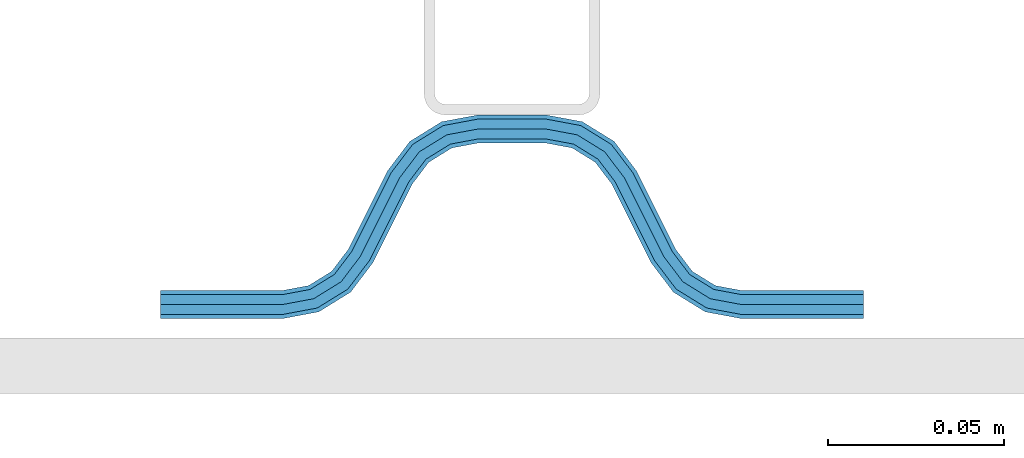
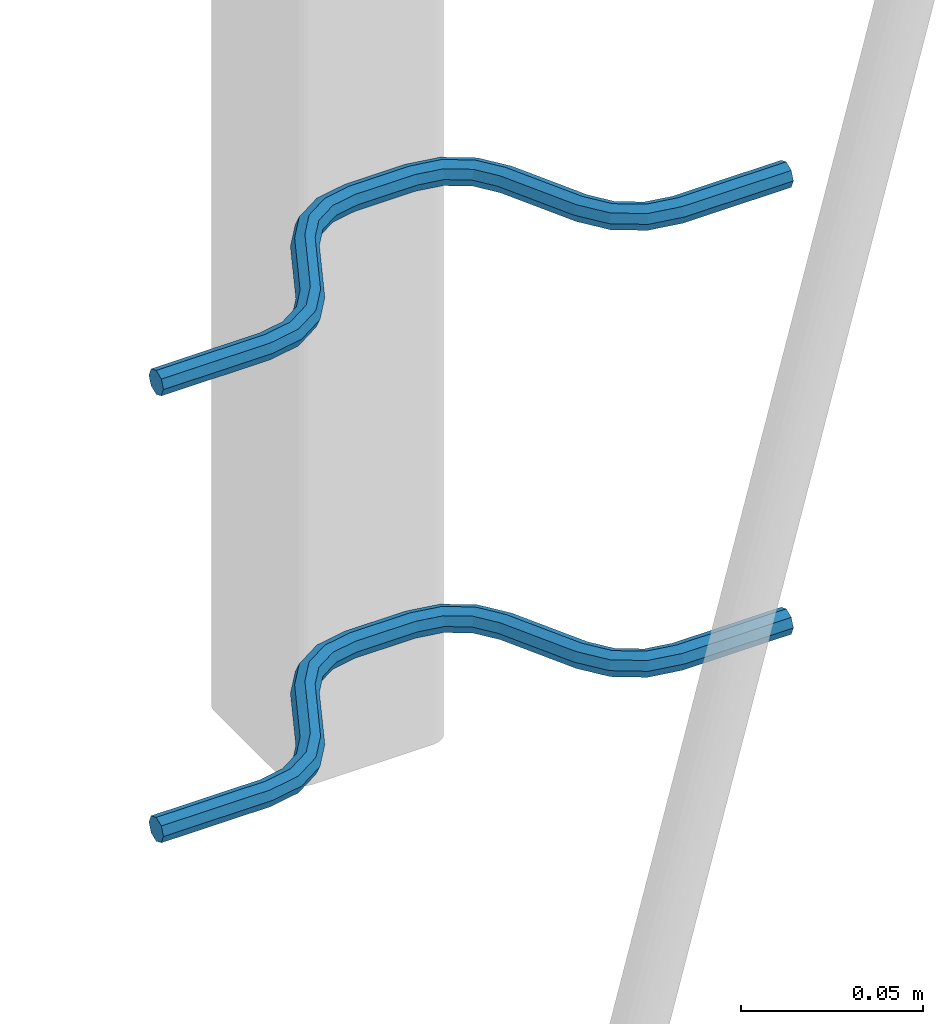
# One storey, part 5 of 5: 2 beams, 2 elements without a shape of their own.
"""IFC2X3 building model written with IfcOpenShell, lengths in millimetres."""

import ifcopenshell
import ifcopenshell.guid

model = None  # the IFC model being written
_history = None  # IfcOwnerHistory: only IFC2X3 demands one
_inside = {}  # id of a spatial element -> (the spatial element, [elements in it])
_under = {}  # id of a project, library or spatial element -> (it, [spatial elements below it])
_declared = {}  # id of a project -> (the project, [libraries it declares])
_typed = {}  # id of a type object -> (the type object, [elements of that type])
_made_of = {}  # id of a material, layer set ... -> (it, [elements and type objects made of it])


def new_model(schema):
    """Start an empty IFC model of exactly this schema.

    Asked for "IFC4X3", IfcOpenShell would pick the latest addendum, in which some entities
    have other attributes; the version numbers below select the first issue.
    IFC2X3 requires an IfcOwnerHistory on every rooted entity: one is made here for all.
    """
    global model, _history
    if schema == "IFC4X3":
        model = ifcopenshell.file(schema_version=(4, 3, 0, 0))
    else:
        model = ifcopenshell.file(schema=schema)
    _inside.clear()
    _under.clear()
    _declared.clear()
    _typed.clear()
    _made_of.clear()
    _history = None
    if model.schema == "IFC2X3":
        org = make("IfcOrganization", Name="unknown")
        user = make(
            "IfcPersonAndOrganization",
            ThePerson=make("IfcPerson", FamilyName="unknown"),
            TheOrganization=org,
        )
        app = make(
            "IfcApplication",
            ApplicationDeveloper=org,
            Version="unknown",
            ApplicationFullName="unknown",
            ApplicationIdentifier="unknown",
        )
        _history = make(
            "IfcOwnerHistory",
            OwningUser=user,
            OwningApplication=app,
            ChangeAction="ADDED",
            CreationDate=0,
        )
    return model


def make(cls, **values):
    """One entity of the class cls with the attributes given. An attribute that is None is left unset."""
    return model.create_entity(
        cls, **{name: value for name, value in values.items() if value is not None}
    )


def rooted(cls, **values):
    """An entity with a GlobalId (a new one), such as an element, a storey or a relation."""
    return make(cls, GlobalId=ifcopenshell.guid.new(), OwnerHistory=_history, **values)


def si_unit(unit_type, name, prefix=None):
    """IfcSIUnit, for example si_unit("LENGTHUNIT", "METRE", prefix="MILLI")."""
    return make("IfcSIUnit", UnitType=unit_type, Prefix=prefix, Name=name)


def assignment(units):
    """IfcUnitAssignment: the units of a project."""
    return None if units is None else make("IfcUnitAssignment", Units=units)


def point(xyz):
    """IfcCartesianPoint."""
    return None if xyz is None else make("IfcCartesianPoint", Coordinates=xyz)


def direction(xyz):
    """IfcDirection."""
    return None if xyz is None else make("IfcDirection", DirectionRatios=xyz)


def frame(location, z_axis=None, x_axis=None):
    """IfcAxis2Placement3D, a coordinate frame: its origin and axes. An axis left out is left unset."""
    return make(
        "IfcAxis2Placement3D",
        Location=point(location),
        Axis=direction(z_axis),
        RefDirection=direction(x_axis),
    )


def origin_with_axes():
    """The frame at (0, 0, 0) with the z axis (0, 0, 1) and the x axis (1, 0, 0) written out."""
    return frame((0.0, 0.0, 0.0), z_axis=(0.0, 0.0, 1.0), x_axis=(1.0, 0.0, 0.0))


def place(relative_to, where):
    """IfcLocalPlacement: puts the frame where relative to a parent placement (None: the world)."""
    return make(
        "IfcLocalPlacement", PlacementRelTo=relative_to, RelativePlacement=where
    )


def context(
    kind, dimensions, precision=None, world=None, true_north=None, identifier=None
):
    """IfcGeometricRepresentationContext, for example the 3D "Model" context."""
    return make(
        "IfcGeometricRepresentationContext",
        ContextIdentifier=identifier,
        ContextType=kind,
        CoordinateSpaceDimension=dimensions,
        Precision=precision,
        WorldCoordinateSystem=world,
        TrueNorth=true_north,
    )


def subcontext(parent, identifier, kind, view, scale=None):
    """IfcGeometricRepresentationSubContext, for example "Body" below "Model"."""
    return make(
        "IfcGeometricRepresentationSubContext",
        ContextIdentifier=identifier,
        ContextType=kind,
        ParentContext=parent,
        TargetScale=scale,
        TargetView=view,
    )


def project(units=None, contexts=None):
    """IfcProject with its units and contexts."""
    return rooted(
        "IfcProject",
        Name="project",
        RepresentationContexts=contexts,
        UnitsInContext=assignment(units),
    )


def spatial(cls, under=None, at=None, **own):
    """A site, building, storey or space (cls), placed at a placement, below another one or the project."""
    s = rooted(cls, ObjectPlacement=at, **own)
    if under is not None:
        _under.setdefault(under.id(), (under, []))[1].append(s)
    return s


def faces_of(points, faces, orient=None, outer=None):
    """IfcFace entities. A face is a list of loops; a loop is a list of indices into points, from 0.

    orient and outer hold one flag for each loop. By default every Orientation is true, the
    first loop of a face is its IfcFaceOuterBound and the others are IfcFaceBound.
    """
    made = []
    for i, loops in enumerate(faces):
        bounds = []
        for j, loop in enumerate(loops):
            is_outer = j == 0 if outer is None else outer[i][j]
            bounds.append(
                make(
                    "IfcFaceOuterBound" if is_outer else "IfcFaceBound",
                    Bound=make("IfcPolyLoop", Polygon=[points[k] for k in loop]),
                    Orientation=True if orient is None else orient[i][j],
                )
            )
        made.append(make("IfcFace", Bounds=bounds))
    return made


def faceted_brep(points, faces, orient=None, outer=None, voids=None):
    """IfcFacetedBrep: a solid bounded by flat faces; with voids (closed shells), ...WithVoids."""
    shared = [point(p) for p in points]
    hull = make("IfcClosedShell", CfsFaces=faces_of(shared, faces, orient, outer))
    if voids is None:
        return make("IfcFacetedBrep", Outer=hull)
    return make(
        "IfcFacetedBrepWithVoids",
        Outer=hull,
        Voids=[
            make(cls, CfsFaces=faces_of(shared, fs, o, b)) for cls, fs, o, b in voids
        ],
    )


def shape(context_of_items, identifier, shape_type, items):
    """IfcShapeRepresentation: the items that make up one representation, for example the "Body"."""
    return make(
        "IfcShapeRepresentation",
        ContextOfItems=context_of_items,
        RepresentationIdentifier=identifier,
        RepresentationType=shape_type,
        Items=items,
    )


def material(Name=None, Category=None):
    """IfcMaterial."""
    return make("IfcMaterial", Name=Name, Category=Category)


def made_of(thing, what):
    """Note that an element or type object is made of a material, layer set ...; save() writes the relation."""
    if what is not None:
        _made_of.setdefault(what.id(), (what, []))[1].append(thing)
    return thing


def type_object(cls, material=None, **own):
    """A type object (cls), such as IfcWallType, which elements share."""
    return made_of(rooted(cls, **own), material)


def element(
    cls,
    number,
    at=None,
    inside=None,
    cuts=None,
    type_object=None,
    material=None,
    context=None,
    identifier="Body",
    shape_type=None,
    held_by="IfcProductDefinitionShape",
    body=None,
    shapes=None,
    **own,
):
    """One element of the class cls, such as IfcWall. Its Tag is "e" and its number.

    at: its placement. inside: the storey or other place that contains it. cuts: it is an
    opening in that element (IfcRelVoidsElement). A single representation is given by context,
    identifier, shape_type and body (its items); several are given by shapes. held_by: the class
    of the entity that holds the representations. save() writes the other relations.
    """
    e = rooted(cls, Tag="e%d" % number, ObjectPlacement=at, **own)
    if body is not None:
        shapes = [shape(context, identifier, shape_type, body)]
    if shapes is not None:
        e.Representation = make(held_by, Representations=shapes)
    if inside is not None:
        _inside.setdefault(inside.id(), (inside, []))[1].append(e)
    if cuts is not None:
        rooted(
            "IfcRelVoidsElement", RelatingBuildingElement=cuts, RelatedOpeningElement=e
        )
    if type_object is not None:
        _typed.setdefault(type_object.id(), (type_object, []))[1].append(e)
    return made_of(e, material)


def aggregate(whole, parts):
    """IfcRelAggregates: a whole, such as a stair, and the parts it consists of."""
    return rooted("IfcRelAggregates", RelatingObject=whole, RelatedObjects=parts)


def save(model, path):
    """Write the relations noted so far, then the file.

    IfcRelAggregates (storeys below a building ...), IfcRelContainedInSpatialStructure (elements
    in a storey), IfcRelDefinesByType, IfcRelAssociatesMaterial and IfcRelDeclares: one each for
    every whole, place, type object, material and project.
    """
    for whole, parts in _under.values():
        aggregate(whole, parts)
    for where, things in _inside.values():
        rooted(
            "IfcRelContainedInSpatialStructure",
            RelatedElements=things,
            RelatingStructure=where,
        )
    for kind, things in _typed.values():
        rooted("IfcRelDefinesByType", RelatedObjects=things, RelatingType=kind)
    for what, things in _made_of.values():
        rooted("IfcRelAssociatesMaterial", RelatedObjects=things, RelatingMaterial=what)
    for by, libraries in _declared.values():
        rooted("IfcRelDeclares", RelatingContext=by, RelatedDefinitions=libraries)
    model.write(path)


model = new_model("IFC2X3")

# Units and contexts
model_context = context("Model", 3, precision=1e-05, world=origin_with_axes())
body_context = subcontext(model_context, "Body", "Model", "MODEL_VIEW")
ifc_project = project(units=[si_unit("LENGTHUNIT", "METRE", prefix="MILLI"), si_unit("AREAUNIT", "SQUARE_METRE"), si_unit("VOLUMEUNIT", "CUBIC_METRE"), si_unit("MASSUNIT", "GRAM", prefix="KILO"), si_unit("TIMEUNIT", "SECOND"), si_unit("PLANEANGLEUNIT", "RADIAN"), si_unit("SOLIDANGLEUNIT", "STERADIAN"), si_unit("THERMODYNAMICTEMPERATUREUNIT", "DEGREE_CELSIUS"), si_unit("LUMINOUSINTENSITYUNIT", "LUMEN")], contexts=[model_context])

# Site, building, storey
site_placement = place(None, origin_with_axes())
site = spatial("IfcSite", under=ifc_project, at=site_placement, CompositionType="ELEMENT")
building_placement = place(site_placement, origin_with_axes())
building = spatial("IfcBuilding", under=site, at=building_placement, Name="Undefined", CompositionType="ELEMENT")
storey_placement = place(building_placement, origin_with_axes())
storey = spatial("IfcBuildingStorey", under=building, at=storey_placement, Name="Undefined", CompositionType="ELEMENT", Elevation=0.0)

# Assembly, beam
assembly_1_placement = place(storey_placement, origin_with_axes())
assembly_1 = element("IfcElementAssembly", 1, at=assembly_1_placement, inside=storey, Name="Steel Assembly", AssemblyPlace="NOTDEFINED", PredefinedType="NOTDEFINED")
ifc_material = material(Name="REBAR/A500HW")
beam_type = type_object("IfcBeamType", Name="D8", PredefinedType="NOTDEFINED")
beam_1_placement = place(assembly_1_placement, frame((44320.002893764, 6595.91435022475, 2580.99992151562), z_axis=(0.0, 0.0, 1.0), x_axis=(-0.999999999544916, 3.01690000137701e-05, 0.0)))
beam_1 = element("IfcBeam", 2, at=beam_1_placement, type_object=beam_type, material=ifc_material, Name="AnchorRebar", ObjectType="D8", context=body_context, shape_type="Brep", body=[
    faceted_brep([(3.97994881495833e-09, -4.00000000000091, 0.0), (2.8085196390748e-09, -2.82842712474758, -2.82842712474621), (34.5491497841067, -2.82842709033048, -2.82842712474621), (34.5491497849507, -3.99999996579936, 0.0), (-7.27595761418343e-12, -9.09494701772928e-13, -4.0), (34.5491497812909, 3.44161890097894e-08, -4.0), (-2.82307155430317e-09, 2.82842712474485, -2.82842712474621), (34.5491497784751, 2.82842715916104, -2.82842712474621), (-3.9945007301867e-09, 3.99999999999909, 0.0), (34.5491497773037, 4.00000003441619, 0.0), (-2.82307155430317e-09, 2.82842712474485, 2.82842712474621), (34.5491497784751, 2.82842715916104, 2.82842712474621), (-7.27595761418343e-12, -9.09494701772928e-13, 4.0), (34.5491497812909, 3.44161890097894e-08, 4.0), (2.8085196390748e-09, -2.82842712474758, 2.82842712474621), (34.5491497841067, -2.82842709033048, 2.82842712474621), (45.0102956714691, 2.04744773578568, 0.0), (44.5876751631804, 0.954756147099033, -2.82842712474621), (43.5673790003711, -1.68323470581527, -4.0), (42.5470828375619, -4.3212255587232, -2.82842712474621), (42.1244623293023, -5.41391714741258, 0.0), (42.5470828375619, -4.3212255587232, 2.82842712474621), (43.5673790003711, -1.68323470581527, 4.0), (44.5876751631804, 0.954756147099033, 2.82842712474621), (53.274424971547, -4.41395065588222, 2.82842712474621), (54.0627564272581, -3.5472808699069, 0.0), (51.3712244794879, -6.50627660728151, 4.0), (49.4680239874506, -8.59860255868261, 2.82842712474621), (48.6796925317176, -9.4652723446543, 0.0), (49.4680239874506, -8.59860255868261, -2.82842712474621), (51.3712244794879, -6.50627660728151, -4.0), (53.274424971547, -4.41395065588222, -2.82842712474621), (59.4396520724549, -12.5547497421876, 2.82842712474621), (60.4875387236025, -12.0308064548954, 0.0), (56.9098299073739, -13.8196607322834, 4.0), (54.3800077422784, -15.0845717223683, 2.82842712474621), (53.3321210918803, -15.6085150094559, 0.0), (54.3800077422784, -15.0845717223683, -2.82842712474621), (56.9098299073739, -13.8196607322834, -4.0), (59.4396520724549, -12.5547497421876, -2.82842712474621), (65.5603461982682, -37.4452502676068, -2.82842712474621), (64.5124595463058, -37.9691935549445, 0.0), (68.0901683634002, -36.1803392775319, -4.0), (70.6199905285321, -34.9154282874579, -2.82842712474621), (71.6678771797233, -34.3914850001738, 0.0), (70.6199905285321, -34.9154282874579, 2.82842712474621), (68.0901683634002, -36.1803392775319, 4.0), (65.5603461982682, -37.4452502676068, 2.82842712474621), (76.3203055137128, -40.5347274610476, 0.0), (75.5319740454433, -41.4013972356079, -2.82842712474621), (73.628773523058, -43.4937231594477, -4.0), (71.7255730006873, -45.586049083292, -2.82842712474621), (70.9372415324033, -46.4527188578513, 0.0), (71.7255730006873, -45.586049083292, 2.82842712474621), (73.628773523058, -43.4937231594477, 4.0), (75.5319740454433, -41.4013972356079, 2.82842712474621), (82.4529148344736, -45.6787742201832, 2.82842712474621), (82.8755353743836, -44.5860826437265, 0.0), (81.4326185952377, -48.3167650435544, 4.0), (80.4123223560309, -50.9547558669201, 2.82842712474621), (79.9897018161209, -52.0474474433813, 0.0), (80.4123223560309, -50.9547558669201, -2.82842712474621), (81.4326185952377, -48.3167650435544, -4.0), (82.4529148344736, -45.6787742201832, -2.82842712474621), (90.4508475245966, -47.1715729199359, 2.82842712474621), (90.4508475742841, -46.000000044688, 0.0), (90.4508474046088, -50.0000000446771, 4.0), (90.4508472846428, -52.8284271694056, 2.82842712474621), (90.4508472356392, -54.0000000440459, 0.0), (90.4508472846428, -52.8284271694056, -2.82842712474621), (90.4508474046088, -50.0000000446771, -4.0), (90.4508475245966, -47.1715729199359, -2.82842712474621), (109.549147724516, -52.8284279786703, -2.82842712474621), (109.54914767341, -54.0000008540392, 0.0), (109.54914784446, -50.0000008539246, -4.0), (109.549147964404, -47.171573729177, -2.82842712474621), (109.549148014084, -46.0000008539246, 0.0), (109.549147964404, -47.171573729177, 2.82842712474621), (109.54914784446, -50.0000008539246, 4.0), (109.549147724516, -52.8284279786703, 2.82842712474621), (120.010293570755, -52.0474490194165, 0.0), (119.58767311088, -50.954757411987, 2.82842712474621), (118.567377064988, -48.316766513838, 4.0), (117.547081019067, -45.6787756156891, 2.82842712474621), (117.124460559222, -44.586084008266, 0.0), (117.547081019067, -45.6787756156891, -2.82842712474621), (118.567377064988, -48.316766513838, -4.0), (119.58767311088, -50.954757411987, -2.82842712474621), (128.274423097741, -45.5860510482489, -2.82842712474621), (129.062754512561, -46.4527208714499, 0.0), (126.371222704453, -43.4937250069761, -4.0), (124.468022311172, -41.4013989657033, -2.82842712474621), (123.679690896359, -40.5347291425014, 0.0), (124.468022311172, -41.4013989657033, 2.82842712474621), (126.371222704453, -43.4937250069761, 4.0), (128.274423097741, -45.5860510482489, 2.82842712474621), (134.439650547101, -37.4452523250511, -2.82842712474621), (135.487537173387, -37.9691956638335, 0.0), (131.909828445358, -36.1803412081899, -4.0), (129.380006343621, -34.9154300913378, -2.82842712474621), (128.332119718681, -34.3914867515423, 0.0), (129.380006343621, -34.9154300913378, 2.82842712474621), (131.909828445358, -36.1803412081899, 4.0), (134.439650547101, -37.4452523250511, 2.82842712474621), (145.619991993379, -15.0845705988722, -2.82842712474621), (146.66787861682, -15.6085139395227, 0.0), (143.090169891606, -13.8196594820974, -4.0), (140.560347789826, -12.5547483653227, -2.82842712474621), (139.512461164864, -12.0308050255589, 0.0), (140.560347789826, -12.5547483653227, 2.82842712474621), (143.090169891606, -13.8196594820974, 4.0), (145.619991993379, -15.0845705988722, 2.82842712474621), (151.32030721409, -9.46527175248229, 0.0), (150.531975786696, -8.59860194074281, 2.82842712474621), (148.62877536298, -6.50627592714864, 4.0), (146.725574939279, -4.41394991354628, 2.82842712474621), (145.937243511864, -3.5472801018077, 0.0), (146.725574939279, -4.41394991354628, -2.82842712474621), (148.62877536298, -6.50627592714864, -4.0), (150.531975786696, -8.59860194074281, -2.82842712474621), (157.452916717564, -4.32122530571087, -2.82842712474621), (157.875537209118, -5.41391690087676, 0.0), (156.432620595137, -1.68323443716054, -4.0), (155.412324472702, 0.95475643138434, -2.82842712474621), (154.989703981155, 2.04744802655023, 0.0), (155.412324472702, 0.95475643138434, 2.82842712474621), (156.432620595137, -1.68323443716054, 4.0), (157.452916717564, -4.32122530571087, 2.82842712474621), (165.450849409564, -2.82842696003536, -2.82842712474621), (165.450849412795, -3.99999983546877, 0.0), (165.450849406625, 1.64712218975183e-07, -4.0), (165.450849403685, 2.82842728945616, -2.82842712474621), (165.45084940247, 4.00000016471495, 0.0), (165.450849403685, 2.82842728945616, 2.82842712474621), (165.450849406625, 1.64712218975183e-07, 4.0), (165.450849409564, -2.82842696003536, 2.82842712474621), (200.000000091874, -2.82842692587838, -2.82842712474621), (200.000000093038, -3.99999980113171, 0.0), (200.000000089065, 1.98867383005563e-07, -4.0), (200.000000086249, 2.82842732361496, -2.82842712474621), (200.000000085085, 4.00000019886738, 0.0), (200.000000086249, 2.82842732361496, 2.82842712474621), (200.000000089065, 1.98867383005563e-07, 4.0), (200.000000091874, -2.82842692587838, 2.82842712474621)], [[[0, 1, 2, 3]], [[1, 4, 5, 2]], [[4, 6, 7, 5]], [[6, 8, 9, 7]], [[8, 10, 11, 9]], [[10, 12, 13, 11]], [[12, 14, 15, 13]], [[14, 0, 3, 15]], [[14, 12, 10, 8, 6, 4, 1, 0]], [[7, 9, 16, 17]], [[5, 7, 17, 18]], [[2, 5, 18, 19]], [[3, 2, 19, 20]], [[15, 3, 20, 21]], [[13, 15, 21, 22]], [[11, 13, 22, 23]], [[9, 11, 23, 16]], [[23, 24, 25, 16]], [[22, 26, 24, 23]], [[21, 27, 26, 22]], [[20, 28, 27, 21]], [[19, 29, 28, 20]], [[18, 30, 29, 19]], [[17, 31, 30, 18]], [[16, 25, 31, 17]], [[24, 32, 33, 25]], [[26, 34, 32, 24]], [[27, 35, 34, 26]], [[28, 36, 35, 27]], [[29, 37, 36, 28]], [[30, 38, 37, 29]], [[31, 39, 38, 30]], [[25, 33, 39, 31]], [[36, 37, 40, 41]], [[37, 38, 42, 40]], [[38, 39, 43, 42]], [[39, 33, 44, 43]], [[33, 32, 45, 44]], [[32, 34, 46, 45]], [[34, 35, 47, 46]], [[35, 36, 41, 47]], [[43, 44, 48, 49]], [[42, 43, 49, 50]], [[40, 42, 50, 51]], [[41, 40, 51, 52]], [[47, 41, 52, 53]], [[46, 47, 53, 54]], [[45, 46, 54, 55]], [[44, 45, 55, 48]], [[55, 56, 57, 48]], [[54, 58, 56, 55]], [[53, 59, 58, 54]], [[52, 60, 59, 53]], [[51, 61, 60, 52]], [[50, 62, 61, 51]], [[49, 63, 62, 50]], [[48, 57, 63, 49]], [[56, 64, 65, 57]], [[58, 66, 64, 56]], [[59, 67, 66, 58]], [[60, 68, 67, 59]], [[61, 69, 68, 60]], [[62, 70, 69, 61]], [[63, 71, 70, 62]], [[57, 65, 71, 63]], [[68, 69, 72, 73]], [[69, 70, 74, 72]], [[70, 71, 75, 74]], [[71, 65, 76, 75]], [[65, 64, 77, 76]], [[64, 66, 78, 77]], [[66, 67, 79, 78]], [[67, 68, 73, 79]], [[79, 73, 80, 81]], [[78, 79, 81, 82]], [[77, 78, 82, 83]], [[76, 77, 83, 84]], [[75, 76, 84, 85]], [[74, 75, 85, 86]], [[72, 74, 86, 87]], [[73, 72, 87, 80]], [[87, 88, 89, 80]], [[86, 90, 88, 87]], [[85, 91, 90, 86]], [[84, 92, 91, 85]], [[83, 93, 92, 84]], [[82, 94, 93, 83]], [[81, 95, 94, 82]], [[80, 89, 95, 81]], [[88, 96, 97, 89]], [[90, 98, 96, 88]], [[91, 99, 98, 90]], [[92, 100, 99, 91]], [[93, 101, 100, 92]], [[94, 102, 101, 93]], [[95, 103, 102, 94]], [[89, 97, 103, 95]], [[97, 96, 104, 105]], [[96, 98, 106, 104]], [[98, 99, 107, 106]], [[99, 100, 108, 107]], [[100, 101, 109, 108]], [[101, 102, 110, 109]], [[102, 103, 111, 110]], [[103, 97, 105, 111]], [[111, 105, 112, 113]], [[110, 111, 113, 114]], [[109, 110, 114, 115]], [[108, 109, 115, 116]], [[107, 108, 116, 117]], [[106, 107, 117, 118]], [[104, 106, 118, 119]], [[105, 104, 119, 112]], [[119, 120, 121, 112]], [[118, 122, 120, 119]], [[117, 123, 122, 118]], [[116, 124, 123, 117]], [[115, 125, 124, 116]], [[114, 126, 125, 115]], [[113, 127, 126, 114]], [[112, 121, 127, 113]], [[120, 128, 129, 121]], [[122, 130, 128, 120]], [[123, 131, 130, 122]], [[124, 132, 131, 123]], [[125, 133, 132, 124]], [[126, 134, 133, 125]], [[127, 135, 134, 126]], [[121, 129, 135, 127]], [[129, 128, 136, 137]], [[128, 130, 138, 136]], [[130, 131, 139, 138]], [[131, 132, 140, 139]], [[132, 133, 141, 140]], [[133, 134, 142, 141]], [[134, 135, 143, 142]], [[135, 129, 137, 143]], [[138, 139, 140, 141, 142, 143, 137, 136]]]),
])
aggregate(assembly_1, [beam_1])

assembly_2_placement = place(storey_placement, origin_with_axes())
assembly_2 = element("IfcElementAssembly", 3, at=assembly_2_placement, inside=storey, Name="Steel Assembly", AssemblyPlace="NOTDEFINED", PredefinedType="NOTDEFINED")
beam_2_placement = place(assembly_2_placement, frame((44320.002893764, 6595.91435022475, 2430.99992151562), z_axis=(0.0, 0.0, 1.0), x_axis=(-0.999999999544916, 3.01690000137701e-05, 0.0)))
beam_2 = element("IfcBeam", 4, at=beam_2_placement, type_object=beam_type, material=ifc_material, Name="AnchorRebar", ObjectType="D8", context=body_context, shape_type="Brep", body=[
    faceted_brep([(3.97994881495833e-09, -4.00000000000091, 0.0), (2.8085196390748e-09, -2.82842712474758, -2.82842712474621), (34.5491497841067, -2.82842709033048, -2.82842712474621), (34.5491497849507, -3.99999996579936, 0.0), (-7.27595761418343e-12, -9.09494701772928e-13, -4.0), (34.5491497812909, 3.44161890097894e-08, -4.0), (-2.82307155430317e-09, 2.82842712474485, -2.82842712474621), (34.5491497784751, 2.82842715916104, -2.82842712474621), (-3.9945007301867e-09, 3.99999999999909, 0.0), (34.5491497773037, 4.00000003441619, 0.0), (-2.82307155430317e-09, 2.82842712474485, 2.82842712474621), (34.5491497784751, 2.82842715916104, 2.82842712474621), (-7.27595761418343e-12, -9.09494701772928e-13, 4.0), (34.5491497812909, 3.44161890097894e-08, 4.0), (2.8085196390748e-09, -2.82842712474758, 2.82842712474621), (34.5491497841067, -2.82842709033048, 2.82842712474621), (45.0102956714691, 2.04744773578568, 0.0), (44.5876751631804, 0.954756147099033, -2.82842712474621), (43.5673790003711, -1.68323470581527, -4.0), (42.5470828375619, -4.3212255587232, -2.82842712474621), (42.1244623293023, -5.41391714741258, 0.0), (42.5470828375619, -4.3212255587232, 2.82842712474621), (43.5673790003711, -1.68323470581527, 4.0), (44.5876751631804, 0.954756147099033, 2.82842712474621), (53.274424971547, -4.41395065588222, 2.82842712474621), (54.0627564272581, -3.5472808699069, 0.0), (51.3712244794879, -6.50627660728151, 4.0), (49.4680239874506, -8.59860255868261, 2.82842712474621), (48.6796925317176, -9.4652723446543, 0.0), (49.4680239874506, -8.59860255868261, -2.82842712474621), (51.3712244794879, -6.50627660728151, -4.0), (53.274424971547, -4.41395065588222, -2.82842712474621), (59.4396520724549, -12.5547497421876, 2.82842712474621), (60.4875387236025, -12.0308064548954, 0.0), (56.9098299073739, -13.8196607322834, 4.0), (54.3800077422784, -15.0845717223683, 2.82842712474621), (53.3321210918803, -15.6085150094559, 0.0), (54.3800077422784, -15.0845717223683, -2.82842712474621), (56.9098299073739, -13.8196607322834, -4.0), (59.4396520724549, -12.5547497421876, -2.82842712474621), (65.5603461982682, -37.4452502676068, -2.82842712474621), (64.5124595463058, -37.9691935549445, 0.0), (68.0901683634002, -36.1803392775319, -4.0), (70.6199905285321, -34.9154282874579, -2.82842712474621), (71.6678771797233, -34.3914850001738, 0.0), (70.6199905285321, -34.9154282874579, 2.82842712474621), (68.0901683634002, -36.1803392775319, 4.0), (65.5603461982682, -37.4452502676068, 2.82842712474621), (76.3203055137128, -40.5347274610476, 0.0), (75.5319740454433, -41.4013972356079, -2.82842712474621), (73.628773523058, -43.4937231594477, -4.0), (71.7255730006873, -45.586049083292, -2.82842712474621), (70.9372415324033, -46.4527188578513, 0.0), (71.7255730006873, -45.586049083292, 2.82842712474621), (73.628773523058, -43.4937231594477, 4.0), (75.5319740454433, -41.4013972356079, 2.82842712474621), (82.4529148344736, -45.6787742201832, 2.82842712474621), (82.8755353743836, -44.5860826437265, 0.0), (81.4326185952377, -48.3167650435544, 4.0), (80.4123223560309, -50.9547558669201, 2.82842712474621), (79.9897018161209, -52.0474474433813, 0.0), (80.4123223560309, -50.9547558669201, -2.82842712474621), (81.4326185952377, -48.3167650435544, -4.0), (82.4529148344736, -45.6787742201832, -2.82842712474621), (90.4508475245966, -47.1715729199359, 2.82842712474621), (90.4508475742841, -46.000000044688, 0.0), (90.4508474046088, -50.0000000446771, 4.0), (90.4508472846428, -52.8284271694056, 2.82842712474621), (90.4508472356392, -54.0000000440459, 0.0), (90.4508472846428, -52.8284271694056, -2.82842712474621), (90.4508474046088, -50.0000000446771, -4.0), (90.4508475245966, -47.1715729199359, -2.82842712474621), (109.549147724516, -52.8284279786703, -2.82842712474621), (109.54914767341, -54.0000008540392, 0.0), (109.54914784446, -50.0000008539246, -4.0), (109.549147964404, -47.171573729177, -2.82842712474621), (109.549148014084, -46.0000008539246, 0.0), (109.549147964404, -47.171573729177, 2.82842712474621), (109.54914784446, -50.0000008539246, 4.0), (109.549147724516, -52.8284279786703, 2.82842712474621), (120.010293570755, -52.0474490194165, 0.0), (119.58767311088, -50.954757411987, 2.82842712474621), (118.567377064988, -48.316766513838, 4.0), (117.547081019067, -45.6787756156891, 2.82842712474621), (117.124460559222, -44.586084008266, 0.0), (117.547081019067, -45.6787756156891, -2.82842712474621), (118.567377064988, -48.316766513838, -4.0), (119.58767311088, -50.954757411987, -2.82842712474621), (128.274423097741, -45.5860510482489, -2.82842712474621), (129.062754512561, -46.4527208714499, 0.0), (126.371222704453, -43.4937250069761, -4.0), (124.468022311172, -41.4013989657033, -2.82842712474621), (123.679690896359, -40.5347291425014, 0.0), (124.468022311172, -41.4013989657033, 2.82842712474621), (126.371222704453, -43.4937250069761, 4.0), (128.274423097741, -45.5860510482489, 2.82842712474621), (134.439650547101, -37.4452523250511, -2.82842712474621), (135.487537173387, -37.9691956638335, 0.0), (131.909828445358, -36.1803412081899, -4.0), (129.380006343621, -34.9154300913378, -2.82842712474621), (128.332119718681, -34.3914867515423, 0.0), (129.380006343621, -34.9154300913378, 2.82842712474621), (131.909828445358, -36.1803412081899, 4.0), (134.439650547101, -37.4452523250511, 2.82842712474621), (145.619991993379, -15.0845705988722, -2.82842712474621), (146.66787861682, -15.6085139395227, 0.0), (143.090169891606, -13.8196594820974, -4.0), (140.560347789826, -12.5547483653227, -2.82842712474621), (139.512461164864, -12.0308050255589, 0.0), (140.560347789826, -12.5547483653227, 2.82842712474621), (143.090169891606, -13.8196594820974, 4.0), (145.619991993379, -15.0845705988722, 2.82842712474621), (151.32030721409, -9.46527175248229, 0.0), (150.531975786696, -8.59860194074281, 2.82842712474621), (148.62877536298, -6.50627592714864, 4.0), (146.725574939279, -4.41394991354628, 2.82842712474621), (145.937243511864, -3.5472801018077, 0.0), (146.725574939279, -4.41394991354628, -2.82842712474621), (148.62877536298, -6.50627592714864, -4.0), (150.531975786696, -8.59860194074281, -2.82842712474621), (157.452916717564, -4.32122530571087, -2.82842712474621), (157.875537209118, -5.41391690087676, 0.0), (156.432620595137, -1.68323443716054, -4.0), (155.412324472702, 0.95475643138434, -2.82842712474621), (154.989703981155, 2.04744802655023, 0.0), (155.412324472702, 0.95475643138434, 2.82842712474621), (156.432620595137, -1.68323443716054, 4.0), (157.452916717564, -4.32122530571087, 2.82842712474621), (165.450849409564, -2.82842696003536, -2.82842712474621), (165.450849412795, -3.99999983546877, 0.0), (165.450849406625, 1.64712218975183e-07, -4.0), (165.450849403685, 2.82842728945616, -2.82842712474621), (165.45084940247, 4.00000016471495, 0.0), (165.450849403685, 2.82842728945616, 2.82842712474621), (165.450849406625, 1.64712218975183e-07, 4.0), (165.450849409564, -2.82842696003536, 2.82842712474621), (200.000000091874, -2.82842692587838, -2.82842712474621), (200.000000093038, -3.99999980113171, 0.0), (200.000000089065, 1.98867383005563e-07, -4.0), (200.000000086249, 2.82842732361496, -2.82842712474621), (200.000000085085, 4.00000019886738, 0.0), (200.000000086249, 2.82842732361496, 2.82842712474621), (200.000000089065, 1.98867383005563e-07, 4.0), (200.000000091874, -2.82842692587838, 2.82842712474621)], [[[0, 1, 2, 3]], [[1, 4, 5, 2]], [[4, 6, 7, 5]], [[6, 8, 9, 7]], [[8, 10, 11, 9]], [[10, 12, 13, 11]], [[12, 14, 15, 13]], [[14, 0, 3, 15]], [[14, 12, 10, 8, 6, 4, 1, 0]], [[7, 9, 16, 17]], [[5, 7, 17, 18]], [[2, 5, 18, 19]], [[3, 2, 19, 20]], [[15, 3, 20, 21]], [[13, 15, 21, 22]], [[11, 13, 22, 23]], [[9, 11, 23, 16]], [[23, 24, 25, 16]], [[22, 26, 24, 23]], [[21, 27, 26, 22]], [[20, 28, 27, 21]], [[19, 29, 28, 20]], [[18, 30, 29, 19]], [[17, 31, 30, 18]], [[16, 25, 31, 17]], [[24, 32, 33, 25]], [[26, 34, 32, 24]], [[27, 35, 34, 26]], [[28, 36, 35, 27]], [[29, 37, 36, 28]], [[30, 38, 37, 29]], [[31, 39, 38, 30]], [[25, 33, 39, 31]], [[36, 37, 40, 41]], [[37, 38, 42, 40]], [[38, 39, 43, 42]], [[39, 33, 44, 43]], [[33, 32, 45, 44]], [[32, 34, 46, 45]], [[34, 35, 47, 46]], [[35, 36, 41, 47]], [[43, 44, 48, 49]], [[42, 43, 49, 50]], [[40, 42, 50, 51]], [[41, 40, 51, 52]], [[47, 41, 52, 53]], [[46, 47, 53, 54]], [[45, 46, 54, 55]], [[44, 45, 55, 48]], [[55, 56, 57, 48]], [[54, 58, 56, 55]], [[53, 59, 58, 54]], [[52, 60, 59, 53]], [[51, 61, 60, 52]], [[50, 62, 61, 51]], [[49, 63, 62, 50]], [[48, 57, 63, 49]], [[56, 64, 65, 57]], [[58, 66, 64, 56]], [[59, 67, 66, 58]], [[60, 68, 67, 59]], [[61, 69, 68, 60]], [[62, 70, 69, 61]], [[63, 71, 70, 62]], [[57, 65, 71, 63]], [[68, 69, 72, 73]], [[69, 70, 74, 72]], [[70, 71, 75, 74]], [[71, 65, 76, 75]], [[65, 64, 77, 76]], [[64, 66, 78, 77]], [[66, 67, 79, 78]], [[67, 68, 73, 79]], [[79, 73, 80, 81]], [[78, 79, 81, 82]], [[77, 78, 82, 83]], [[76, 77, 83, 84]], [[75, 76, 84, 85]], [[74, 75, 85, 86]], [[72, 74, 86, 87]], [[73, 72, 87, 80]], [[87, 88, 89, 80]], [[86, 90, 88, 87]], [[85, 91, 90, 86]], [[84, 92, 91, 85]], [[83, 93, 92, 84]], [[82, 94, 93, 83]], [[81, 95, 94, 82]], [[80, 89, 95, 81]], [[88, 96, 97, 89]], [[90, 98, 96, 88]], [[91, 99, 98, 90]], [[92, 100, 99, 91]], [[93, 101, 100, 92]], [[94, 102, 101, 93]], [[95, 103, 102, 94]], [[89, 97, 103, 95]], [[97, 96, 104, 105]], [[96, 98, 106, 104]], [[98, 99, 107, 106]], [[99, 100, 108, 107]], [[100, 101, 109, 108]], [[101, 102, 110, 109]], [[102, 103, 111, 110]], [[103, 97, 105, 111]], [[111, 105, 112, 113]], [[110, 111, 113, 114]], [[109, 110, 114, 115]], [[108, 109, 115, 116]], [[107, 108, 116, 117]], [[106, 107, 117, 118]], [[104, 106, 118, 119]], [[105, 104, 119, 112]], [[119, 120, 121, 112]], [[118, 122, 120, 119]], [[117, 123, 122, 118]], [[116, 124, 123, 117]], [[115, 125, 124, 116]], [[114, 126, 125, 115]], [[113, 127, 126, 114]], [[112, 121, 127, 113]], [[120, 128, 129, 121]], [[122, 130, 128, 120]], [[123, 131, 130, 122]], [[124, 132, 131, 123]], [[125, 133, 132, 124]], [[126, 134, 133, 125]], [[127, 135, 134, 126]], [[121, 129, 135, 127]], [[129, 128, 136, 137]], [[128, 130, 138, 136]], [[130, 131, 139, 138]], [[131, 132, 140, 139]], [[132, 133, 141, 140]], [[133, 134, 142, 141]], [[134, 135, 143, 142]], [[135, 129, 137, 143]], [[138, 139, 140, 141, 142, 143, 137, 136]]]),
])
aggregate(assembly_2, [beam_2])

save(model, "model.ifc")
